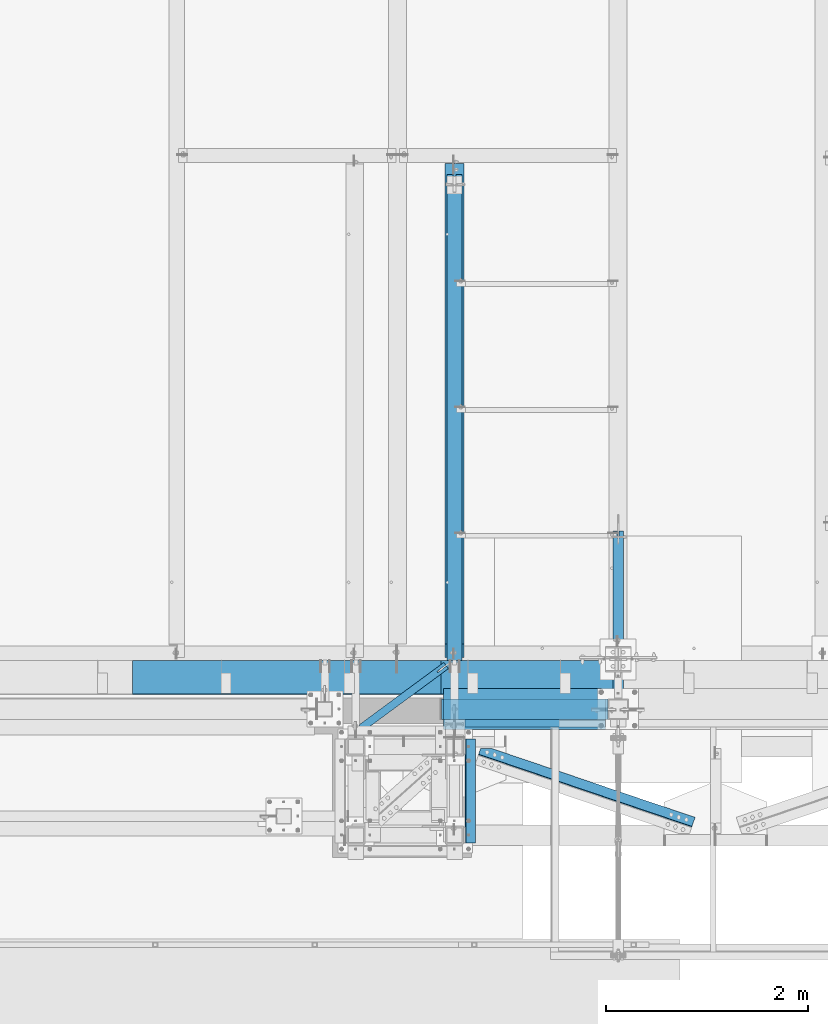
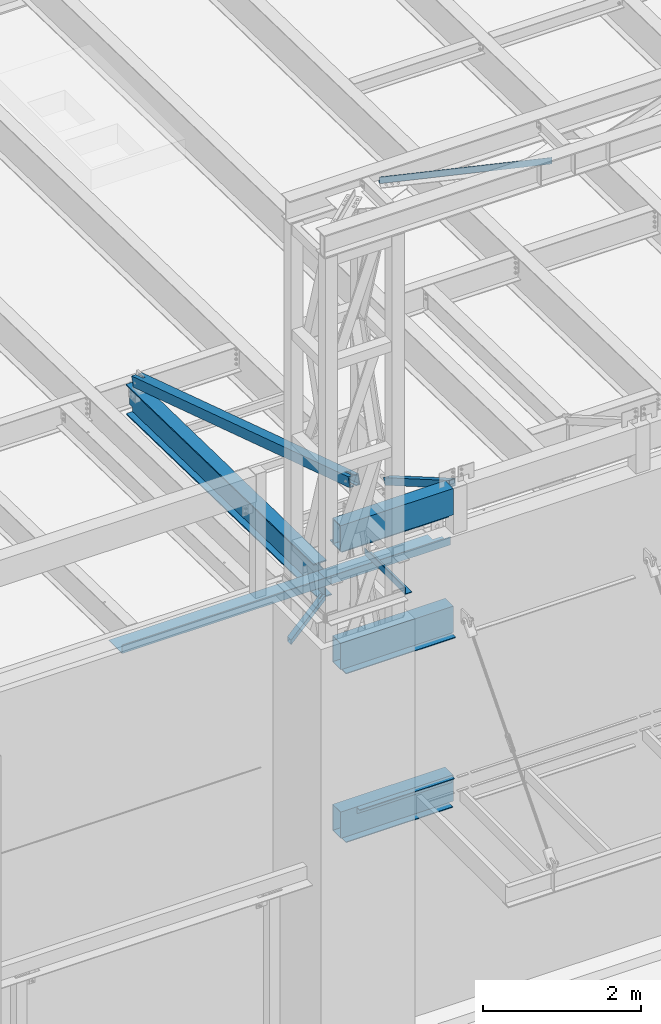
# One storey, part 1054 of 1763: 14 beams, 1 member, 10 elements without a shape of their own.
"""IFC2X3 building model written with IfcOpenShell, lengths in millimetres."""

from ifc_helpers import new_model, si_unit, frame, origin_with_axes, place, context, subcontext, project, spatial, faceted_brep, material, type_object, element, aggregate, save


model = new_model("IFC2X3")

# Units and contexts
model_context = context("Model", 3, precision=1e-05, world=origin_with_axes())
body_context = subcontext(model_context, "Body", "Model", "MODEL_VIEW")
ifc_project = project(units=[si_unit("LENGTHUNIT", "METRE", prefix="MILLI"), si_unit("AREAUNIT", "SQUARE_METRE"), si_unit("VOLUMEUNIT", "CUBIC_METRE"), si_unit("MASSUNIT", "GRAM", prefix="KILO"), si_unit("TIMEUNIT", "SECOND"), si_unit("PLANEANGLEUNIT", "RADIAN"), si_unit("SOLIDANGLEUNIT", "STERADIAN"), si_unit("THERMODYNAMICTEMPERATUREUNIT", "DEGREE_CELSIUS"), si_unit("LUMINOUSINTENSITYUNIT", "LUMEN")], contexts=[model_context])

# Site, building, storey
site_placement = place(None, origin_with_axes())
site = spatial("IfcSite", under=ifc_project, at=site_placement, CompositionType="ELEMENT")
building_placement = place(site_placement, origin_with_axes())
building = spatial("IfcBuilding", under=site, at=building_placement, Name="Undefined", CompositionType="ELEMENT")
storey_placement = place(building_placement, origin_with_axes())
storey = spatial("IfcBuildingStorey", under=building, at=storey_placement, Name="Undefined", CompositionType="ELEMENT", Elevation=0.0)

# Assembly, beam
assembly_1_placement = place(storey_placement, origin_with_axes())
assembly_1 = element("IfcElementAssembly", 1, at=assembly_1_placement, inside=storey, Name="BEAM", AssemblyPlace="NOTDEFINED", PredefinedType="RIGID_FRAME")
ifc_material_1 = material()
beam_type_1 = type_object("IfcBeamType", Name="HSS16X8X5/8", PredefinedType="NOTDEFINED")
beam_1_placement = place(assembly_1_placement, frame((-63347.0275957751, -14208.1276214906, 13055.6221257957), z_axis=(0.0, 0.0, 1.0), x_axis=(1.0, 0.0, 0.0)))
beam_1 = element("IfcBeam", 2, at=beam_1_placement, type_object=beam_type_1, material=ifc_material_1, Name="BEAM", ObjectType="HSS16X8X5/8", context=body_context, shape_type="Brep", body=[
    faceted_brep([(6.35000000000582, 85.7250000000004, -187.325000000001), (6.35000000000582, -85.7250000000004, -187.325000000001), (1651.00058591833, -85.7250000000004, -187.325000000001), (1651.00058591833, 85.7250000000004, -187.325000000001), (6.35000000000582, -85.7250000000004, 187.325000000001), (1651.00058591833, -85.7250000000004, 187.325000000001), (6.35000000000582, 85.7250000000004, 187.325000000001), (1651.00058591833, 85.7250000000004, 187.325000000001), (6.35000010184012, 101.599999999984, -203.200000000001), (6.35000010184012, 101.599999999984, 203.200000000001), (1651.00058591833, 101.6, 203.200000000001), (1651.00058591833, 101.6, -203.200000000001), (6.34999989850257, -101.600000000013, 203.200000000001), (1651.00058591833, -101.6, 203.200000000001), (6.34999989850257, -101.600000000013, -203.200000000001), (1651.00058591833, -101.6, -203.200000000001)], [[[0, 1, 2, 3]], [[1, 4, 5, 2]], [[4, 6, 7, 5]], [[6, 0, 3, 7]], [[8, 9, 10, 11]], [[9, 12, 13, 10]], [[12, 14, 15, 13]], [[14, 8, 11, 15]], [[13, 15, 11, 10], [5, 7, 3, 2]], [[14, 12, 9, 8], [6, 4, 1, 0]]]),
])

assembly_2_placement = place(storey_placement, origin_with_axes())
assembly_2 = element("IfcElementAssembly", 3, at=assembly_2_placement, inside=storey, Name="ANGLE", AssemblyPlace="NOTDEFINED", PredefinedType="RIGID_FRAME")
ifc_material_2 = material(Name="STEEL/A36")
beam_type_2 = type_object("IfcBeamType", Name="L4X4X1/4", PredefinedType="NOTDEFINED")
beam_2_placement = place(assembly_2_placement, frame((-63194.2133129911, -14531.4847593253, 18672.175), z_axis=(0.320655196883025, 0.947195990654473, 0.0), x_axis=(0.947195990654472, -0.320655196883028, 0.0)))
beam_2 = element("IfcBeam", 4, at=beam_2_placement, type_object=beam_type_2, material=ifc_material_2, Name="ANGLE", ObjectType="L4X4X1/4", context=body_context, shape_type="Brep", body=[
    faceted_brep([(248.955943907371, 44.4500000000007, 15.0456579998354), (248.955943907371, 50.7999999999993, 15.0456579998354), (248.955725224791, 50.7999999999993, -50.8000000003522), (248.955725224791, -50.7999999999993, -50.8000000003522), (248.955735543401, -50.7999999999993, -44.4499999997788), (248.955735543401, 44.4500000000007, -44.4499999997788), (354.596617838433, 44.4500000000007, 50.8082961697146), (354.596617838433, 50.7999999999993, 50.8000000001412), (2474.00579815266, -50.7999999999993, -44.4499999983818), (2474.00578204374, -50.7999999999993, -50.8000000031461), (2474.00578204374, 50.7999999999993, -50.8000000031461), (2474.00613183361, 50.7999999999993, 50.8000000014727), (2474.00613183361, 44.4500000000007, 50.8000000014727), (2474.00579815266, 44.4500000000007, -44.4499999983818)], [[[0, 1, 2, 3, 4, 5]], [[6, 7, 1, 0]], [[8, 9, 10, 11, 12, 13]], [[5, 13, 12, 6, 0]], [[8, 13, 5, 4]], [[9, 8, 4, 3]], [[10, 9, 3, 2]], [[11, 10, 2, 1, 7]], [[12, 11, 7, 6]]]),
])
aggregate(assembly_2, [beam_2])

assembly_3_placement = place(storey_placement, origin_with_axes())
assembly_3 = element("IfcElementAssembly", 5, at=assembly_3_placement, inside=storey, Name="BEAM", AssemblyPlace="NOTDEFINED", PredefinedType="RIGID_FRAME")
beam_type_3 = type_object("IfcBeamType", Name="HSS3X3X1/4", PredefinedType="NOTDEFINED")
beam_3_placement = place(assembly_3_placement, frame((-64185.2277910131, -14433.7160235076, 11825.2875), z_axis=(0.0, 0.0, 1.0), x_axis=(0.805254059732427, 0.592929927802979, 0.0)))
beam_3 = element("IfcBeam", 6, at=beam_3_placement, type_object=beam_type_3, material=ifc_material_1, Name="BEAM", ObjectType="HSS3X3X1/4", context=body_context, shape_type="Brep", body=[
    faceted_brep([(1107.48844328983, 6.37417618212567, 38.1000000000004), (999.541056084388, 6.39964000033433, 38.1000000000004), (999.541056084388, 6.39964000033433, 31.75), (1107.48844328983, 6.37417618212567, 31.75), (999.53806026862, -6.30035964624039, 38.1000000000004), (999.53806026862, -6.30035964624403, 31.75), (1107.4884432898, -6.32582417114099, 38.1000000000004), (1107.4884432898, -6.32582417114099, 31.75), (1107.48844328983, 6.37417618212567, -31.75), (999.541056084367, 6.39964000033433, -31.75), (999.541056084367, 6.39964000033433, -38.1000000000004), (1107.48844328983, 6.37417618212567, -38.1000000000004), (999.538060268591, -6.30035964624767, -31.75), (999.538060268591, -6.30035964624767, -38.1000000000004), (1107.4884432898, -6.32582417114099, -31.75), (1107.4884432898, -6.32582417114099, -38.1000000000004), (70.6926274011275, 31.7499999998654, 31.75), (70.6926274011275, 31.7499999998654, -31.75), (1107.48844328988, 31.7499999987231, -31.75), (1107.48844328988, 31.7499999987231, 31.75), (1107.48844328976, -31.7500000011605, 31.75), (23.935892727568, -31.7499999999709, 31.75), (23.935892727568, -31.7499999999709, -31.75), (1107.48844328976, -31.7500000011605, -31.75), (19.2602192602208, -38.0999999999585, -38.1000000000004), (19.2602192602208, -38.0999999999585, 38.1000000000004), (75.368300868482, 38.0999999998494, 38.1000000000004), (75.368300868482, 38.0999999998494, -38.1000000000004), (1107.48844328989, 38.0999999987143, 38.1000000000004), (1107.48844328989, 38.0999999987143, -38.1000000000004), (1107.48844328975, -38.1000000011518, -38.1000000000004), (1107.48844328975, -38.1000000011518, 38.1000000000004)], [[[0, 1, 2, 3]], [[4, 5, 2, 1]], [[6, 7, 5, 4]], [[8, 9, 10, 11]], [[12, 13, 10, 9]], [[14, 15, 13, 12]], [[16, 17, 18, 19]], [[20, 21, 16, 19, 3, 2, 5, 7]], [[22, 21, 20, 23]], [[9, 8, 18, 17, 22, 23, 14, 12]], [[24, 25, 26, 27], [16, 21, 22, 17]], [[27, 26, 28, 29]], [[19, 18, 8, 11, 29, 28, 0, 3]], [[30, 24, 27, 29, 11, 10, 13, 15]], [[25, 24, 30, 31]], [[1, 0, 28, 26, 25, 31, 6, 4]], [[31, 30, 15, 14, 23, 20, 7, 6]]]),
])
aggregate(assembly_3, [beam_3])

assembly_4_placement = place(storey_placement, origin_with_axes())
assembly_4 = element("IfcElementAssembly", 7, at=assembly_4_placement, inside=storey, Name="V. BRACE", AssemblyPlace="NOTDEFINED", PredefinedType="RIGID_FRAME")
beam_type_4 = type_object("IfcBeamType", Name="HSS6X6X1/2", PredefinedType="NOTDEFINED")
beam_4_placement = place(assembly_4_placement, frame((-63211.0608225783, -14490.7023151462, 14001.7707184966), z_axis=(0.0, 0.306784151144964, 0.951779115449726), x_axis=(0.0, 0.951779115449727, -0.306784151144964)))
beam_4 = element("IfcBeam", 8, at=beam_4_placement, type_object=beam_type_4, material=ifc_material_1, Name="V. BRACE", ObjectType="HSS6X6X1/2", context=body_context, shape_type="Brep", body=[
    faceted_brep([(64.5916172349789, 14.2874999999985, 76.2000000000317), (64.5916172349789, 14.2874999999985, 63.5000000000218), (274.141621753359, 14.2874999999985, 63.4999999999272), (274.141621753362, 14.2874999999985, 76.1999999999389), (274.141621753362, -14.2874988555923, 76.1999999999389), (274.141621753359, -14.2874988555923, 63.4999999999272), (64.5916172349789, -14.2874988555923, 63.5000000000218), (64.5916172349789, -14.2874988555923, 76.2000000000317), (64.5916172349753, 14.2874999999985, -63.5000000000764), (64.5916172349753, 14.2874999999985, -76.2000000000844), (274.141621753297, 14.2874999999985, -76.200000000179), (274.141621753301, 14.2874999999985, -63.500000000171), (274.141621753301, -14.2874988555923, -63.500000000171), (274.141621753297, -14.2874988555923, -76.200000000179), (64.5916172349753, -14.2874988555923, -76.2000000000844), (64.5916172349753, -14.2874988555923, -63.5000000000764), (64.5916172349789, 63.5, 63.5000000000218), (64.5916172349753, 63.5, -63.5000000000764), (5820.2575051603, 63.5, -63.5000000026248), (5820.2575051603, 63.5, 63.4999999974752), (64.5916172349753, 76.1999999999971, -76.2000000000844), (5820.2575051603, 76.1999999999971, -76.2000000026346), (5820.2575051603, 14.2874999409978, -76.2000000026346), (5629.75750516893, 14.2874984164446, -76.200000002551), (5629.75750539753, -14.2875004392699, -76.200000002551), (5820.2575051603, -14.287498914593, -76.2000000026346), (5820.2575051603, -76.1999999999971, -76.2000000026346), (64.5916172349753, -76.1999999999971, -76.2000000000844), (5820.2575051603, 14.2874999480191, -63.5000000026248), (5629.75750516893, 14.2874984234659, -63.5000000025411), (5629.75750539754, -14.2875004322486, -63.5000000025411), (5820.25750516775, -14.2874989075717, -63.5000000026266), (64.5916172349753, -63.5, -63.5000000000764), (64.5916172349789, -63.5, 63.5000000000218), (5820.2575051603, -63.5, 63.4999999974752), (5820.2575051603, -63.5, -63.5000000026248), (5629.7575053976, -14.2875003549998, 76.1999999975669), (5629.75750539759, -14.2875003620211, 63.4999999975589), (5629.75750516899, 14.2874984936934, 63.4999999975589), (5629.75750516899, 14.2874985007147, 76.1999999975687), (5820.25750516781, -14.2874988303229, 76.1999999974832), (5820.2575051603, -14.2874988373442, 63.4999999974752), (5820.2575051603, -76.1999999999971, 76.1999999974851), (64.5916172349789, -76.1999999999971, 76.2000000000317), (5820.2575051603, 14.2875000182466, 63.4999999974752), (5820.2575051603, 14.2875000252679, 76.1999999974851), (5820.2575051603, 76.1999999999971, 76.1999999974851), (64.5916172349789, 76.1999999999971, 76.2000000000317)], [[[0, 1, 2, 3]], [[4, 5, 6, 7]], [[3, 2, 5, 4]], [[8, 9, 10, 11]], [[12, 13, 14, 15]], [[11, 10, 13, 12]], [[16, 17, 18, 19]], [[9, 20, 21, 22, 23, 24, 25, 26, 27, 14, 13, 10]], [[28, 29, 23, 22]], [[30, 24, 23, 29]], [[31, 25, 24, 30]], [[32, 33, 34, 35]], [[36, 37, 38, 39]], [[40, 41, 37, 36]], [[42, 26, 25, 31, 35, 34, 41, 40]], [[43, 27, 26, 42]], [[33, 32, 15, 14, 27, 43, 7, 6]], [[1, 16, 19, 44, 38, 37, 41, 34, 33, 6, 5, 2]], [[45, 39, 38, 44]], [[19, 18, 28, 22, 21, 46, 45, 44]], [[20, 47, 46, 21]], [[43, 42, 40, 36, 39, 45, 46, 47, 0, 3, 4, 7]], [[47, 20, 9, 8, 17, 16, 1, 0]], [[32, 35, 31, 30, 29, 28, 18, 17, 8, 11, 12, 15]]]),
])
aggregate(assembly_4, [beam_4])

assembly_5_placement = place(storey_placement, origin_with_axes())
assembly_5 = element("IfcElementAssembly", 9, at=assembly_5_placement, inside=storey, Name="FRAME", AssemblyPlace="NOTDEFINED", PredefinedType="RIGID_FRAME")
beam_type_5 = type_object("IfcBeamType", Name="L4X4X3/8", PredefinedType="NOTDEFINED")
beam_5_placement = place(assembly_5_placement, frame((-63054.9275957005, -14503.4023212497, 12903.2000061035), z_axis=(1.0, 0.0, 0.0), x_axis=(0.0, -1.0, 0.0)))
beam_5 = element("IfcBeam", 10, at=beam_5_placement, type_object=beam_type_5, material=ifc_material_2, Name="ANGLE", ObjectType="L4X4X3/8", context=body_context, shape_type="Brep", body=[
    faceted_brep([(-3.63797880709171e-11, 50.8000000000011, -50.8000000000538), (-1.96450855582952e-10, 50.8000000000393, 50.7999999999374), (1025.5249938965, 50.7999999999993, 50.8000000000029), (1025.5249938965, 50.7999999999993, -50.8000000000029), (0.0, 41.2749999999996, 50.7999999999993), (1025.5249938965, 41.2749999999996, 50.8000000000029), (0.0, 41.2749999999996, -41.2750000000015), (1025.5249938965, 41.2749999999996, -41.2750000000015), (0.0, -50.7999999999993, -41.2750000000015), (1025.5249938965, -50.7999999999993, -41.2750000000015), (2.11002770811319e-10, -50.8000000000357, -50.799999999952), (1025.5249938965, -50.7999999999993, -50.8000000000029)], [[[0, 1, 2, 3]], [[1, 4, 5, 2]], [[4, 6, 7, 5]], [[6, 8, 9, 7]], [[8, 10, 11, 9]], [[10, 0, 3, 11]], [[5, 7, 9, 11, 3, 2]], [[10, 8, 6, 4, 1, 0]]]),
])
aggregate(assembly_5, [beam_5])

assembly_6_placement = place(storey_placement, origin_with_axes())
assembly_6 = element("IfcElementAssembly", 11, at=assembly_6_placement, inside=storey, Name="BEAM", AssemblyPlace="NOTDEFINED", PredefinedType="RIGID_FRAME")
beam_type_6 = type_object("IfcBeamType", Name="HSS16X8X1/4", PredefinedType="NOTDEFINED")
beam_6_placement = place(assembly_6_placement, frame((-63347.027591527, -14208.1276214906, 11239.5), z_axis=(0.0, 0.0, 1.0), x_axis=(1.0, 0.0, 0.0)))
beam_6 = element("IfcBeam", 12, at=beam_6_placement, type_object=beam_type_6, material=ifc_material_1, Name="BEAM", ObjectType="HSS16X8X1/4", context=body_context, shape_type="Brep", body=[
    faceted_brep([(6.35000009548457, 95.2499999999854, -196.85), (6.3499999048563, -95.2500000000146, -196.85), (1651.00058167023, -95.25, -196.85), (1651.00058167023, 95.25, -196.85), (6.3499999048563, -95.2500000000146, 196.85), (1651.00058167023, -95.25, 196.85), (6.35000009548457, 95.2499999999854, 196.85), (1651.00058167023, 95.25, 196.85), (6.35000010184012, 101.599999999984, -203.200000000001), (6.35000010184012, 101.599999999984, 203.200000000001), (1651.00058591833, 101.6, 203.200000000001), (1651.00058591833, 101.6, -203.200000000001), (6.34999989850257, -101.600000000013, 203.200000000001), (1651.00058591833, -101.6, 203.200000000001), (6.34999989850257, -101.600000000013, -203.200000000001), (1651.00058591833, -101.6, -203.200000000001)], [[[0, 1, 2, 3]], [[1, 4, 5, 2]], [[4, 6, 7, 5]], [[6, 0, 3, 7]], [[8, 9, 10, 11]], [[9, 12, 13, 10]], [[12, 14, 15, 13]], [[14, 8, 11, 15]], [[13, 15, 11, 10], [5, 7, 3, 2]], [[14, 12, 9, 8], [6, 4, 1, 0]]]),
])

assembly_7_placement = place(storey_placement, origin_with_axes())
assembly_7 = element("IfcElementAssembly", 13, at=assembly_7_placement, inside=storey, Name="BEAM", AssemblyPlace="NOTDEFINED", PredefinedType="RIGID_FRAME")
beam_7_placement = place(assembly_7_placement, frame((-63347.0275957006, -14208.1276214906, 8636.0), z_axis=(0.0, 0.0, 1.0), x_axis=(1.0, 0.0, 0.0)))
beam_7 = element("IfcBeam", 14, at=beam_7_placement, type_object=beam_type_6, material=ifc_material_1, Name="BEAM", ObjectType="HSS16X8X1/4", context=body_context, shape_type="Brep", body=[
    faceted_brep([(6.35000009548457, 95.2499999999854, -196.85), (6.3499999048563, -95.2500000000146, -196.85), (1651.00058167023, -95.25, -196.85), (1651.00058167023, 95.25, -196.85), (6.3499999048563, -95.2500000000146, 196.85), (1651.00058167023, -95.25, 196.85), (6.35000009548457, 95.2499999999854, 196.85), (1651.00058167023, 95.25, 196.85), (6.35000010184012, 101.599999999984, -203.200000000001), (6.35000010184012, 101.599999999984, 203.200000000001), (1651.00058591833, 101.6, 203.200000000001), (1651.00058591833, 101.6, -203.200000000001), (6.34999989850257, -101.600000000013, 203.200000000001), (1651.00058591833, -101.6, 203.200000000001), (6.34999989850257, -101.600000000013, -203.200000000001), (1651.00058591833, -101.6, -203.200000000001)], [[[0, 1, 2, 3]], [[1, 4, 5, 2]], [[4, 6, 7, 5]], [[6, 0, 3, 7]], [[8, 9, 10, 11]], [[9, 12, 13, 10]], [[12, 14, 15, 13]], [[14, 8, 11, 15]], [[13, 15, 11, 10], [5, 7, 3, 2]], [[14, 12, 9, 8], [6, 4, 1, 0]]]),
])

# Assembly, member
assembly_8_placement = place(storey_placement, origin_with_axes())
assembly_8 = element("IfcElementAssembly", 15, at=assembly_8_placement, inside=storey, Name="V. BRACE", AssemblyPlace="NOTDEFINED", PredefinedType="RIGID_FRAME")
member_type = type_object("IfcMemberType", Name="HSS4X4X3/8", PredefinedType="NOTDEFINED")
member_placement = place(assembly_8_placement, frame((-61594.4372752341, -14106.5252983474, 13182.6000019665), z_axis=(0.0, 0.50173172990702, 0.865023277839683), x_axis=(0.0, 0.865023198927323, -0.501731865957846)))
member = element("IfcMember", 16, at=member_placement, type_object=member_type, material=ifc_material_1, Name="V. BRACE", ObjectType="HSS4X4X3/8", context=body_context, shape_type="Brep", body=[
    faceted_brep([(1886.82133111547, 7.93799800872512, 50.8000000000629), (1804.27132806142, 7.93799800872512, 50.8000000000575), (1804.27132806142, 7.93799800872512, 41.2750000000651), (1886.82133111547, 7.93799800872512, 41.2750000000688), (1804.27132806142, -7.93700008392625, 50.8000000000575), (1804.27132806142, -7.93700008392625, 41.2750000000651), (1886.82133111301, -7.93700008392625, 50.8000000000629), (1886.82133111547, -7.93700008392625, 41.2750000000688), (1886.82133111547, 7.93799800872512, -41.2749999998769), (1804.27132806142, 7.93799800872512, -41.2749999998814), (1804.27132806142, 7.93799800872512, -50.7999999998738), (1886.82133111547, 7.93799800872512, -50.7999999998719), (1804.27132806142, -7.93700008392625, -41.2749999998814), (1804.27132806142, -7.93700008392625, -50.7999999998738), (1886.82133111302, -7.93700008392625, -41.2749999998759), (1886.82133111547, -7.93700008392625, -50.7999999998719), (-23.943093575228, 41.2750000000015, 41.2749999999705), (23.9376633641841, 41.2750000000015, -41.2749999999724), (1886.82133111547, 41.2750000000015, -41.2749999998769), (1886.82133111547, 41.2750000000015, 41.2750000000688), (1886.82133111547, -41.2750000000015, 41.2750000000688), (-23.943093575228, -41.2750000000015, 41.2749999999705), (23.9376633641841, -41.2750000000015, -41.2749999999724), (1886.82133111547, -41.2750000000015, -41.2749999998769), (29.4623660879624, -50.8000000000029, -50.7999999999665), (-29.4677962990063, -50.8000000000029, 50.7999999999647), (-29.4677962990063, 50.8000000000029, 50.7999999999647), (29.4623660879624, 50.8000000000029, -50.7999999999665), (1886.82133111547, 50.8000000000029, 50.8000000000629), (1886.82133111547, 50.8000000000029, -50.7999999998719), (1886.82133111547, -50.8000000000029, -50.7999999998719), (1886.82133111547, -50.8000000000029, 50.8000000000629)], [[[0, 1, 2, 3]], [[4, 5, 2, 1]], [[6, 7, 5, 4]], [[8, 9, 10, 11]], [[12, 13, 10, 9]], [[14, 15, 13, 12]], [[16, 17, 18, 19]], [[20, 21, 16, 19, 3, 2, 5, 7]], [[22, 21, 20, 23]], [[9, 8, 18, 17, 22, 23, 14, 12]], [[24, 25, 26, 27], [16, 21, 22, 17]], [[27, 26, 28, 29]], [[19, 18, 8, 11, 29, 28, 0, 3]], [[30, 24, 27, 29, 11, 10, 13, 15]], [[25, 24, 30, 31]], [[1, 0, 28, 26, 25, 31, 6, 4]], [[31, 30, 15, 14, 23, 20, 7, 6]]]),
])
aggregate(assembly_8, [member])

# Beam
beam_type_7 = type_object("IfcBeamType", Name="L4X3X3/8", PredefinedType="NOTDEFINED")
beam_8_placement = place(assembly_7_placement, frame((-61721.4268379578, -14347.8276511316, 8788.4), z_axis=(0.0, 0.0, -1.0), x_axis=(-1.0, 0.0, 0.0)))
beam_8 = element("IfcBeam", 17, at=beam_8_placement, type_object=beam_type_7, material=ifc_material_2, Name="ANGLE", ObjectType="L4X3X3/8", context=body_context, shape_type="Brep", body=[
    faceted_brep([(1.45519152283669e-10, 38.0999999999985, -50.7999999999993), (1.45519152283669e-10, 38.0999999999985, 50.7999999999993), (1384.30054943346, 38.0999999994729, 50.7999999999993), (1384.30054943346, 38.0999999994729, -50.7999999999993), (1.09139364212751e-10, 28.5749999999989, 50.7999999999993), (1384.30054943349, 28.5749999994714, 50.7999999999993), (1.09139364212751e-10, 28.5749999999989, -41.2749999999996), (1384.30054943349, 28.5749999994714, -41.2749999999996), (-1.23691279441118e-10, -38.1000000000022, -41.2749999999996), (1384.3005494337, -38.1000000005279, -41.2749999999996), (-1.23691279441118e-10, -38.1000000000022, -50.7999999999993), (1384.3005494337, -38.1000000005279, -50.7999999999993)], [[[0, 1, 2, 3]], [[1, 4, 5, 2]], [[4, 6, 7, 5]], [[6, 8, 9, 7]], [[8, 10, 11, 9]], [[10, 0, 3, 11]], [[5, 7, 9, 11, 3, 2]], [[10, 8, 6, 4, 1, 0]]]),
])

beam_type_8 = type_object("IfcBeamType", PredefinedType="NOTDEFINED")
beam_9_placement = place(assembly_1_placement, frame((-63321.6292414683, -14157.327657643, 12846.1187862029), z_axis=(0.0, 1.0, 0.0), x_axis=(0.999999999994883, 4.99999977045952e-09, -3.19899999977773e-06)))
beam_9 = element("IfcBeam", 18, at=beam_9_placement, type_object=beam_type_8, material=ifc_material_2, Name="PLATE", context=body_context, shape_type="Brep", body=[
    faceted_brep([(-2.11002770811319e-10, 6.34999999999854, -152.4), (2.25554686039686e-10, 6.34999999999854, 152.4), (1562.09969770951, 6.35000000056243, 152.400000000627), (1562.09969770908, 6.35000000056243, -152.399999999372), (2.11002770811319e-10, -6.34999999999854, 152.399999999998), (1562.09969770947, -6.34999999943648, 152.400000000627), (-2.25554686039686e-10, -6.34999999999854, -152.400000000001), (1562.09969770904, -6.34999999943648, -152.399999999372)], [[[0, 1, 2, 3]], [[1, 4, 5, 2]], [[4, 6, 7, 5]], [[6, 0, 3, 7]], [[5, 7, 3, 2]], [[6, 4, 1, 0]]]),
])

aggregate(assembly_1, [beam_9, beam_1])

beam_10_placement = place(assembly_6_placement, frame((-63321.6278778677, -14258.9276309575, 11029.95), z_axis=(0.0, 1.0, 0.0), x_axis=(1.0, 0.0, 0.0)))
beam_10 = element("IfcBeam", 19, at=beam_10_placement, type_object=beam_type_8, material=ifc_material_2, Name="PLATE", context=body_context, shape_type="Brep", body=[
    faceted_brep([(-2.11002770811319e-10, 6.34999999999854, -152.4), (2.25554686039686e-10, 6.34999999999854, 152.4), (1600.19961255685, 6.35000000043874, 152.400000000644), (1600.19961255642, 6.35000000043874, -152.399999999356), (2.11002770811319e-10, -6.34999999999854, 152.399999999998), (1600.19961255683, -6.34999999955653, 152.400000000642), (-2.25554686039686e-10, -6.34999999999854, -152.400000000001), (1600.1996125564, -6.34999999955653, -152.399999999358)], [[[0, 1, 2, 3]], [[1, 4, 5, 2]], [[4, 6, 7, 5]], [[6, 0, 3, 7]], [[5, 7, 3, 2]], [[6, 4, 1, 0]]]),
])

aggregate(assembly_6, [beam_10, beam_6])

beam_11_placement = place(assembly_7_placement, frame((-63321.6278820413, -14258.9276309575, 8426.45), z_axis=(0.0, 1.0, 0.0), x_axis=(1.0, 0.0, 0.0)))
beam_11 = element("IfcBeam", 20, at=beam_11_placement, type_object=beam_type_8, material=ifc_material_2, Name="PLATE", context=body_context, shape_type="Brep", body=[
    faceted_brep([(-2.11002770811319e-10, 6.34999999999854, -152.4), (2.25554686039686e-10, 6.34999999999854, 152.4), (1562.09969770951, 6.35000000056243, 152.400000000627), (1562.09969770908, 6.35000000056243, -152.399999999372), (2.11002770811319e-10, -6.34999999999854, 152.399999999998), (1562.09969770947, -6.34999999943648, 152.400000000627), (-2.25554686039686e-10, -6.34999999999854, -152.400000000001), (1562.09969770904, -6.34999999943648, -152.399999999372)], [[[0, 1, 2, 3]], [[1, 4, 5, 2]], [[4, 6, 7, 5]], [[6, 0, 3, 7]], [[5, 7, 3, 2]], [[6, 4, 1, 0]]]),
])

aggregate(assembly_7, [beam_8, beam_11, beam_7])

# Assembly, beams
assembly_9_placement = place(storey_placement, origin_with_axes())
assembly_9 = element("IfcElementAssembly", 21, at=assembly_9_placement, inside=storey, Name="BEAM", AssemblyPlace="NOTDEFINED", PredefinedType="RIGID_FRAME")
beam_type_9 = type_object("IfcBeamType", PredefinedType="NOTDEFINED")
beam_12_placement = place(assembly_9_placement, frame((-62470.7372736984, -13728.6998186171, 12207.875), z_axis=(-1.0, 0.0, 0.0), x_axis=(0.0, -1.0, 0.0)))
beam_12 = element("IfcBeam", 22, at=beam_12_placement, type_object=beam_type_9, material=ifc_material_2, Name="BENT_PLATE", context=body_context, shape_type="Brep", body=[
    faceted_brep([(127.000180053707, -3.17499999999927, -736.600006103516), (127.000180053707, 3.17499999999927, -736.600006103516), (127.000180053707, 3.17499999999927, -873.125), (127.000180053707, -3.17499999999927, -873.125), (0.0, -3.17499999999927, -736.600006103516), (0.0, 3.17499999999927, -736.600006103516), (330.200016784669, 3.17499999999927, 873.125), (0.0, 3.17499999999927, 873.125), (0.0, -3.17499999999927, 873.125), (336.550018310547, -3.17499999999927, 873.125), (336.549987792969, 123.825000000001, 873.125), (330.19998779297, 123.824998474123, 873.125), (330.200016784669, 3.17499999999927, -873.125), (330.19998779297, 123.824998474123, -873.125), (336.549987792969, 123.825000000001, -873.125), (336.550018310547, -3.17499999999927, -873.125)], [[[0, 1, 2, 3]], [[4, 5, 1, 0]], [[6, 7, 8, 9, 10, 11]], [[12, 6, 11, 13]], [[10, 14, 13, 11]], [[9, 15, 14, 10]], [[12, 13, 14, 15, 3, 2]], [[7, 6, 12, 2, 1, 5]], [[8, 7, 5, 4]], [[15, 9, 8, 4, 0, 3]]]),
])
beam_13_placement = place(assembly_9_placement, frame((-64867.8622736984, -13728.6998186171, 12207.875), z_axis=(-1.0, 0.0, 0.0), x_axis=(0.0, -1.0, 0.0)))
beam_13 = element("IfcBeam", 23, at=beam_13_placement, type_object=beam_type_9, material=ifc_material_2, Name="BENT_PLATE", context=body_context, shape_type="Brep", body=[
    faceted_brep([(0.0, -3.17499999999927, -1523.99999999999), (0.0, -3.17499999999927, 1524.0), (0.0, 3.17499999999927, 1524.0), (0.0, 3.17499999999927, -1523.99999999999), (330.200016784669, 3.17499999999927, 1524.0), (330.200016784669, 3.17499999999927, -1524.0), (336.550018310547, -3.17499999999927, -1524.0), (336.550018310547, -3.17499999999927, 1524.0), (330.19998779297, 123.824998474123, 1524.0), (330.19998779297, 123.824998474123, -1524.0), (336.549987792969, 123.825000000001, 1524.0), (336.549987792969, 123.825000000001, -1524.0)], [[[0, 1, 2, 3]], [[3, 2, 4, 5]], [[1, 0, 6, 7]], [[5, 4, 8, 9]], [[4, 2, 1, 7, 10, 8]], [[7, 6, 11, 10]], [[6, 0, 3, 5, 9, 11]], [[10, 11, 9, 8]]]),
])
aggregate(assembly_9, [beam_12, beam_13])

# Assembly, beam
assembly_10_placement = place(storey_placement, origin_with_axes())
assembly_10 = element("IfcElementAssembly", 24, at=assembly_10_placement, inside=storey, Name="BEAM", AssemblyPlace="NOTDEFINED", PredefinedType="RIGID_FRAME")
ifc_material_3 = material(Name="STEEL/A992")
beam_type_10 = type_object("IfcBeamType", Name="W18X60", PredefinedType="NOTDEFINED")
beam_14_placement = place(assembly_10_placement, frame((-63211.0608225783, -13720.8484701036, 11972.975632907), z_axis=(0.0, 0.0209013539966291, 0.999781542838788), x_axis=(0.0, 0.999781542776098, -0.0209013569953182)))
beam_14 = element("IfcBeam", 25, at=beam_14_placement, type_object=beam_type_10, material=ifc_material_3, Name="BEAM", ObjectType="W18X60", context=body_context, shape_type="Brep", body=[
    faceted_brep([(4897.03310021962, -5.55625000000146, -214.31250000207), (4897.03310021962, -95.25, -214.31250000207), (4897.03310021961, -95.25, -231.775000002084), (4897.03310021961, 95.25, -231.775000002084), (4897.03310021962, 95.25, -214.31250000207), (4897.03310021962, 5.55625000000146, -214.31250000207), (4897.03310021964, 5.55625000000146, -162.184999821255), (4897.03310021964, -5.55625000000146, -162.184999821255), (4897.99983014223, 5.55625000000146, -157.324920303197), (4897.99983014223, -5.55625000000146, -157.324920303197), (4900.75284404272, 5.55625000000146, -153.204743835033), (4900.75284404272, -5.55625000000146, -153.204743835033), (4904.87302051088, 5.55625000000146, -150.45172993455), (4904.87302051088, -5.55625000000146, -150.45172993455), (4909.73310002894, 5.55625000000146, -149.485000011962), (4909.73310002894, -5.55625000000146, -149.485000011962), (4970.00822181917, -5.55625000000146, -149.485000011982), (4970.00822181917, 5.55625000000146, -149.485000011982), (4897.03310021979, 95.25, 214.312499998294), (4897.03310021979, 5.55625000000146, 214.312499998294), (151.69779689799, 5.55625000000146, 214.312500000124), (151.69779689799, 95.25, 214.312500000124), (29.178197101055, 5.55625000000146, -214.312500000193), (29.178197101055, 95.25, -214.312500000193), (29.5432667473015, 95.25, -231.775000000207), (29.5432667473015, -95.25, -231.775000000207), (29.178197101055, -95.25, -214.312500000193), (29.178197101055, -5.55625000000146, -214.312500000193), (20.9197833404342, -5.55625000000146, 180.715001678715), (20.9197833404342, 5.55625000000146, 180.715001678715), (138.997797088679, -5.55625000000146, 180.715001678671), (138.997797088679, 5.55625000000146, 180.715001678671), (143.857876606737, -5.55625000000146, 181.681731601258), (143.857876606737, 5.55625000000146, 181.681731601258), (147.978053074903, -5.55625000000146, 184.434745501741), (147.978053074903, 5.55625000000146, 184.434745501741), (150.73106697539, -5.55625000000146, 188.554921969906), (150.73106697539, 5.55625000000146, 188.554921969906), (151.697796897983, -5.55625000000146, 193.415001487961), (151.697796897983, 5.55625000000146, 193.415001487961), (4897.03310021979, -95.25, 231.77499999831), (4897.03310021979, 95.25, 231.77499999831), (151.697796897995, 95.25, 231.775000000138), (151.697796897995, -95.25, 231.775000000138), (4897.03310021979, -95.25, 214.312499998294), (151.69779689799, -95.25, 214.312500000124), (4897.03310021979, -5.55625000000146, 214.312499998294), (151.69779689799, -5.55625000000146, 214.312500000124), (4897.03310021978, -5.55625000000146, 212.465001476843), (4897.03310021978, 5.55625000000146, 212.465001476843), (4897.99983014237, -5.55625000000146, 207.604921958786), (4897.99983014237, 5.55625000000146, 207.604921958786), (4900.75284404286, -5.55625000000146, 203.484745490619), (4900.75284404286, 5.55625000000146, 203.484745490619), (4904.87302051102, -5.55625000000146, 200.731731590135), (4904.87302051102, 5.55625000000146, 200.731731590135), (4909.73310002908, -5.55625000000146, 199.765001667542), (4909.73310002908, 5.55625000000146, 199.765001667542), (4962.70682885916, -5.55625000000146, 199.765001667522), (4962.70682885916, 5.55625000000146, 199.765001667522)], [[[0, 1, 2, 3, 4, 5, 6, 7]], [[7, 6, 8, 9]], [[9, 8, 10, 11]], [[11, 10, 12, 13]], [[13, 12, 14, 15]], [[16, 15, 14, 17]], [[18, 19, 20, 21]], [[22, 23, 24, 25, 26, 27, 28, 29]], [[30, 31, 29, 28]], [[32, 33, 31, 30]], [[34, 35, 33, 32]], [[36, 37, 35, 34]], [[38, 39, 37, 36]], [[40, 41, 42, 43]], [[44, 40, 43, 45]], [[46, 44, 45, 47]], [[43, 42, 21, 20, 39, 38, 47, 45]], [[41, 18, 21, 42]], [[40, 44, 46, 48, 49, 19, 18, 41]], [[50, 51, 49, 48]], [[52, 53, 51, 50]], [[54, 55, 53, 52]], [[56, 57, 55, 54]], [[58, 59, 57, 56]], [[59, 58, 16, 17]], [[12, 10, 8, 6, 5, 22, 29, 31, 33, 35, 37, 39, 20, 19, 49, 51, 53, 55, 57, 59, 17, 14]], [[23, 22, 5, 4]], [[24, 23, 4, 3]], [[25, 24, 3, 2]], [[26, 25, 2, 1]], [[27, 26, 1, 0]], [[58, 56, 54, 52, 50, 48, 46, 47, 38, 36, 34, 32, 30, 28, 27, 0, 7, 9, 11, 13, 15, 16]]]),
])
aggregate(assembly_10, [beam_14])

save(model, "model.ifc")
